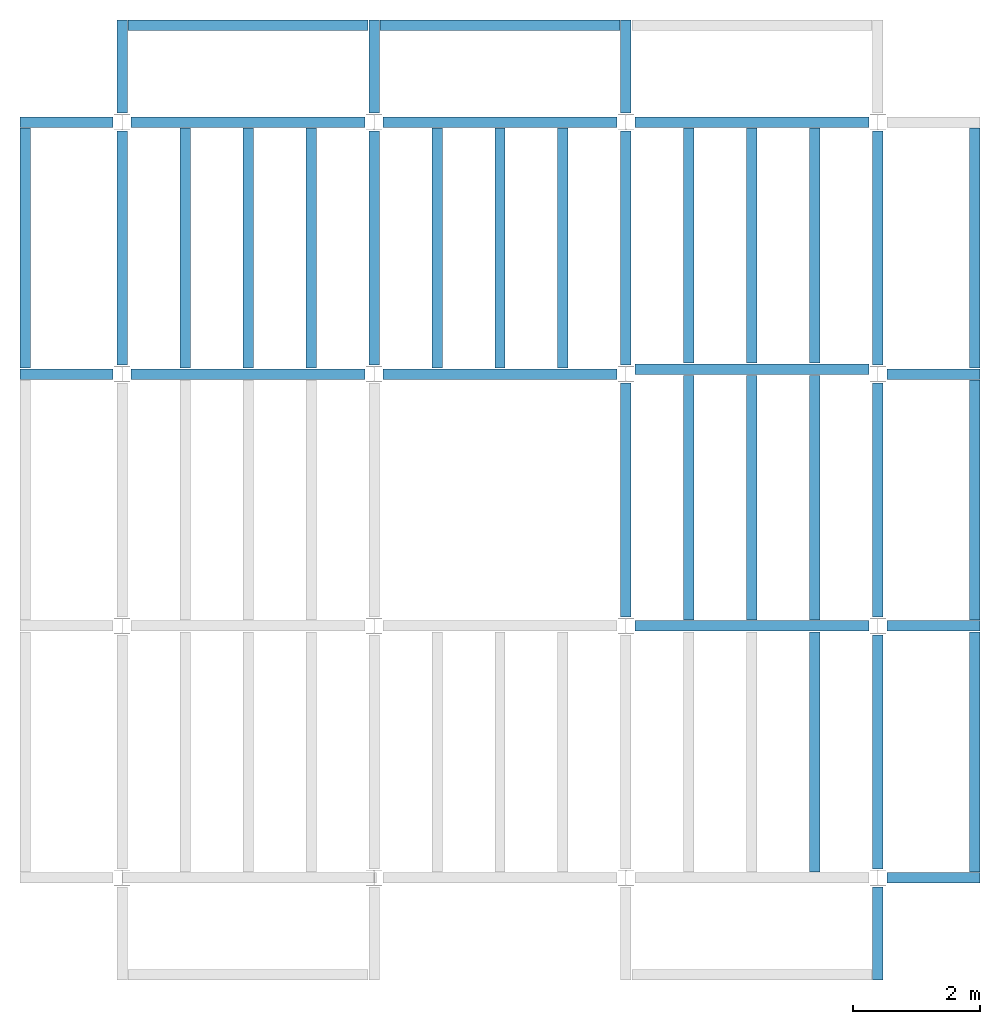
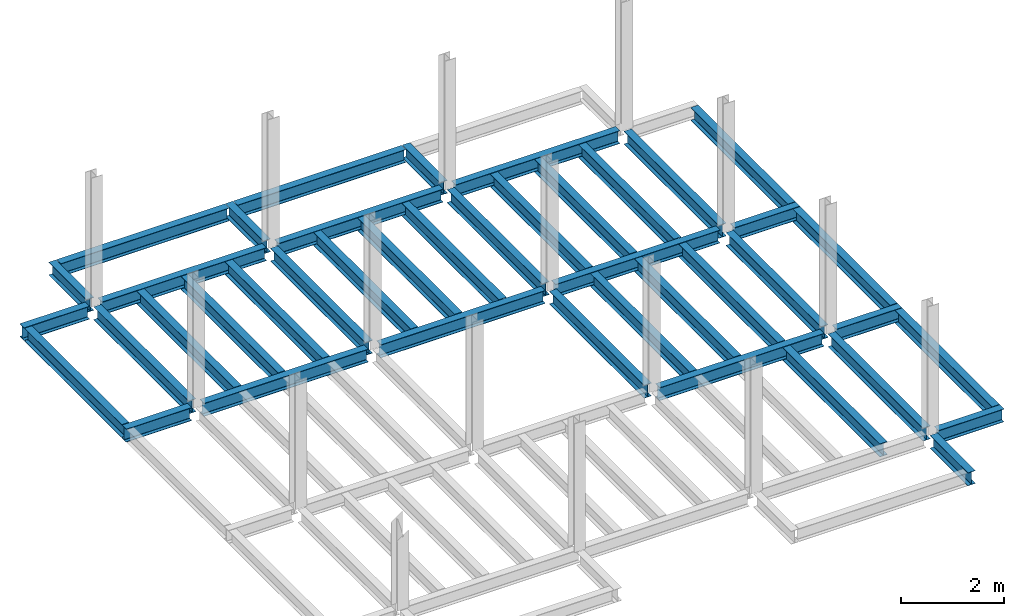
# One storey, part 2 of 3: 42 beams, 5 elements without a shape of their own.
"""IFC4 building model written with IfcOpenShell, lengths in feet."""

from ifc_helpers import new_model, entity, si_unit, converted_unit, derived_unit, direction, frame, origin, place, context, subcontext, project, spatial, line, arc, indexed_curve, outline, extrude, source, transform, mapped, material, type_object, type_shapes, element, aggregate, save


model = new_model("IFC4")

# Units and contexts
model_context = context("Model", 3, precision=0.0001, world=origin(), true_north=direction((6.123233995736766e-17, 1.0)))
plan_context = context("Plan", 3, precision=0.0001, world=origin(), true_north=direction((6.123233995736766e-17, 1.0)))
body_context = subcontext(model_context, "Body", "Model", "MODEL_VIEW")
ifc_project = project(units=[converted_unit("LENGTHUNIT", "FOOT", entity("IfcLengthMeasure", 0.3048), si_unit("LENGTHUNIT", "METRE"), dimensions=[1, 0, 0, 0, 0, 0, 0]), converted_unit("AREAUNIT", "SQUARE FOOT", entity("IfcAreaMeasure", 0.09290304), si_unit("AREAUNIT", "SQUARE_METRE"), dimensions=[2, 0, 0, 0, 0, 0, 0]), converted_unit("PLANEANGLEUNIT", "DEGREE", entity("IfcPlaneAngleMeasure", 0.017453292519943278), si_unit("PLANEANGLEUNIT", "RADIAN"), dimensions=[0, 0, 0, 0, 0, 0, 0]), converted_unit("VOLUMEUNIT", "CUBIC FOOT", entity("IfcVolumeMeasure", 0.028316846592000004), si_unit("VOLUMEUNIT", "CUBIC_METRE"), dimensions=[3, 0, 0, 0, 0, 0, 0]), si_unit("PRESSUREUNIT", "PASCAL"), derived_unit("MASSDENSITYUNIT", [(si_unit("MASSUNIT", "GRAM", prefix="KILO"), 1), (si_unit("LENGTHUNIT", "METRE"), -3)]), derived_unit("VAPORPERMEABILITYUNIT", [(si_unit("LENGTHUNIT", "METRE"), -1), (si_unit("TIMEUNIT", "SECOND"), 1)]), derived_unit("USERDEFINED", [(si_unit("MASSUNIT", "GRAM", prefix="KILO"), 1), (si_unit("LENGTHUNIT", "METRE"), 3), (si_unit("TIMEUNIT", "SECOND"), -3), (si_unit("ELECTRICCURRENTUNIT", "AMPERE"), -2)]), derived_unit("MODULUSOFELASTICITYUNIT", [(si_unit("MASSUNIT", "GRAM", prefix="KILO"), 1), (si_unit("LENGTHUNIT", "METRE"), -1), (si_unit("TIMEUNIT", "SECOND"), -2)]), derived_unit("THERMALEXPANSIONCOEFFICIENTUNIT", [(si_unit("THERMODYNAMICTEMPERATUREUNIT", "KELVIN"), -1)]), derived_unit("SPECIFICHEATCAPACITYUNIT", [(si_unit("TIMEUNIT", "SECOND"), -2), (si_unit("THERMODYNAMICTEMPERATUREUNIT", "KELVIN"), -1), (si_unit("LENGTHUNIT", "METRE"), 2)]), derived_unit("THERMALCONDUCTANCEUNIT", [(si_unit("MASSUNIT", "GRAM", prefix="KILO"), 1), (si_unit("TIMEUNIT", "SECOND"), -3), (si_unit("THERMODYNAMICTEMPERATUREUNIT", "KELVIN"), -1), (si_unit("LENGTHUNIT", "METRE"), 1)])], contexts=[model_context, plan_context])

# Site, building, storey
site_placement = place(None, origin())
site = spatial("IfcSite", under=ifc_project, at=site_placement, CompositionType="ELEMENT")
building_placement = place(site_placement, origin())
building = spatial("IfcBuilding", under=site, at=building_placement, CompositionType="ELEMENT")
storey_placement = place(building_placement, frame((0.0, 0.0, 19.875)))
storey = spatial("IfcBuildingStorey", under=building, at=storey_placement, Name="STR 03", CompositionType="ELEMENT", Elevation=19.875)

# Beams
ifc_material = material(Name="Steel ASTM A992", Category="Metal")
beam_type_1 = type_object("IfcBeamType", Name="W12X26", PredefinedType="JOIST", material=ifc_material)
shared_shape_1 = source(origin(), body_context, "Body", "SweptSolid", [
    extrude(outline(indexed_curve([(-0.27041666666666714, -0.47666666666666574), (-0.27041666666666714, -0.5083333333333351), (0.2704166666666669, -0.5083333333333351), (0.2704166666666669, -0.47666666666666574), (0.03458333333333309, -0.47666666666666574), (0.016905663803669493, -0.46934433619632937), (0.009583333333333202, -0.4516666666666659), (0.0095833333333332, 0.45166666666666705), (0.01690566380366948, 0.4693443361963307), (0.03458333333333325, 0.4766666666666671), (0.2704166666666669, 0.4766666666666671), (0.2704166666666669, 0.5083333333333312), (-0.2704166666666655, 0.5083333333333312), (-0.2704166666666655, 0.4766666666666671), (-0.034583333333333514, 0.47666666666666707), (-0.016905663803669865, 0.46934433619633054), (-0.009583333333333737, 0.45166666666666694), (-0.009583333333333735, -0.4516666666666658), (-0.01690566380367013, -0.4693443361963295), (-0.03458333333333368, -0.47666666666666574)], segments=[line(1, 2, 3, 4, 5), arc(5, 6, 7), line(7, 8), arc(8, 9, 10), line(10, 11, 12, 13, 14, 15), arc(15, 16, 17), line(17, 18), arc(18, 19, 20), line(20, 1)], self_intersect=False)), frame((-6.103346456692914, 0.0, 0.0), z_axis=(-1.0, 0.0, 0.0), x_axis=(0.0, -1.0, 0.0)), (0.0, 0.0, -1.0), 12.083333333333323),
])
type_shapes(beam_type_1, [shared_shape_1])
for number, where, name in (
    (1, (6.561679790026307, 39.0, -0.5083333333333329), "W12X26"),
    (2, (6.561679790026288, 26.0, -0.5083333333333329), "W12X26"),
):
    element("IfcBeam", number, at=place(storey_placement, frame(where)), inside=storey, type_object=beam_type_1, material=ifc_material, Name=name, ObjectType="W Shapes:W12X26", PredefinedType="JOIST", context=body_context, shape_type="MappedRepresentation", body=[
        mapped(shared_shape_1, transform((0.0, 0.0, 0.0), scale=1.0)),
    ])
beam_1_placement = place(storey_placement, frame((39.0, 6.56167979002612, -0.5083333333333329), z_axis=(0.0, 0.0, 1.0), x_axis=(0.0, 1.0, 0.0)))
element("IfcBeam", 3, at=beam_1_placement, inside=storey, type_object=beam_type_1, material=ifc_material, Name="W12X26", ObjectType="W Shapes:W12X26", PredefinedType="JOIST", context=body_context, shape_type="MappedRepresentation", body=[
    mapped(shared_shape_1, transform((0.0, 0.0, 0.0), scale=1.0)),
])
beam_type_2 = type_object("IfcBeamType", Name="W12X26", PredefinedType="JOIST", material=ifc_material)
shared_shape_2 = source(origin(), body_context, "Body", "SweptSolid", [
    extrude(outline(indexed_curve([(-0.27041666666666714, -0.47666666666666574), (-0.27041666666666714, -0.5083333333333351), (0.2704166666666669, -0.5083333333333351), (0.2704166666666669, -0.47666666666666574), (0.03458333333333309, -0.47666666666666574), (0.016905663803669493, -0.46934433619632937), (0.009583333333333202, -0.4516666666666659), (0.0095833333333332, 0.45166666666666705), (0.01690566380366948, 0.4693443361963307), (0.03458333333333325, 0.4766666666666671), (0.2704166666666669, 0.4766666666666671), (0.2704166666666669, 0.5083333333333312), (-0.2704166666666655, 0.5083333333333312), (-0.2704166666666655, 0.4766666666666671), (-0.034583333333333514, 0.47666666666666707), (-0.016905663803669865, 0.46934433619633054), (-0.009583333333333737, 0.45166666666666694), (-0.009583333333333735, -0.4516666666666658), (-0.01690566380367013, -0.4693443361963295), (-0.03458333333333368, -0.47666666666666574)], segments=[line(1, 2, 3, 4, 5), arc(5, 6, 7), line(7, 8), arc(8, 9, 10), line(10, 11, 12, 13, 14, 15), arc(15, 16, 17), line(17, 18), arc(18, 19, 20), line(20, 1)], self_intersect=False)), frame((-6.226706036745409, 0.0, 0.0), z_axis=(-1.0, 0.0, 0.0), x_axis=(0.0, -1.0, 0.0)), (0.0, 0.0, -1.0), 12.08333333333333),
])
type_shapes(beam_type_2, [shared_shape_2])
for number, where, name in (
    (4, (19.685039370078798, 39.0, -0.5083333333333329), "W12X26"),
    (5, (19.68503937007878, 26.0, -0.5083333333333329), "W12X26"),
):
    element("IfcBeam", number, at=place(storey_placement, frame(where)), inside=storey, type_object=beam_type_2, material=ifc_material, Name=name, ObjectType="W Shapes:W12X26", PredefinedType="JOIST", context=body_context, shape_type="MappedRepresentation", body=[
        mapped(shared_shape_2, transform((0.0, 0.0, 0.0), scale=1.0)),
    ])
for number, where, z_axis, x_axis, name in (
    (6, (39.0, 19.685039370078613, -0.5083333333333329), (0.0, 0.0, 1.0), (0.0, 1.0, 0.0), "W12X26"),
    (7, (26.0, 19.685039370078655, -0.5083333333333329), (0.0, 0.0, 1.0), (0.0, 1.0, 0.0), "W12X26"),
):
    element("IfcBeam", number, at=place(storey_placement, frame(where, z_axis=z_axis, x_axis=x_axis)), inside=storey, type_object=beam_type_2, material=ifc_material, Name=name, ObjectType="W Shapes:W12X26", PredefinedType="JOIST", context=body_context, shape_type="MappedRepresentation", body=[
        mapped(shared_shape_2, transform((0.0, 0.0, 0.0), scale=1.0)),
    ])

# Assembly, beams
assembly_1_placement = place(storey_placement, origin())
assembly_1 = element("IfcElementAssembly", 8, at=assembly_1_placement, inside=storey, Name="Structural Framing System", ObjectType="Structural Beam System:Structural Framing System", AssemblyPlace="NOTDEFINED", PredefinedType="BEAM_GRID")
beam_type_3 = type_object("IfcBeamType", Name="W12X26", PredefinedType="JOIST", material=ifc_material)
shared_shape_3 = source(origin(), body_context, "Body", "SweptSolid", [
    extrude(outline(indexed_curve([(-0.27041666666666714, -0.47666666666666574), (-0.27041666666666714, -0.5083333333333351), (0.2704166666666669, -0.5083333333333351), (0.2704166666666669, -0.47666666666666574), (0.03458333333333309, -0.47666666666666574), (0.016905663803669493, -0.46934433619632937), (0.009583333333333202, -0.4516666666666659), (0.0095833333333332, 0.45166666666666705), (0.01690566380366948, 0.4693443361963307), (0.03458333333333325, 0.4766666666666671), (0.2704166666666669, 0.4766666666666671), (0.2704166666666669, 0.5083333333333312), (-0.2704166666666655, 0.5083333333333312), (-0.2704166666666655, 0.4766666666666671), (-0.034583333333333514, 0.47666666666666707), (-0.016905663803669865, 0.46934433619633054), (-0.009583333333333737, 0.45166666666666694), (-0.009583333333333735, -0.4516666666666658), (-0.01690566380367013, -0.4693443361963295), (-0.03458333333333368, -0.47666666666666574)], segments=[line(1, 2, 3, 4, 5), arc(5, 6, 7), line(7, 8), arc(8, 9, 10), line(10, 11, 12, 13, 14, 15), arc(15, 16, 17), line(17, 18), arc(18, 19, 20), line(20, 1)], self_intersect=False)), frame((-6.187916666666566, 0.0, 0.0), z_axis=(-1.0, 0.0, 0.0), x_axis=(0.0, -1.0, 0.0)), (0.0, 0.0, -1.0), 12.375833333333075),
])
type_shapes(beam_type_3, [shared_shape_3])
beam_2_placement = place(assembly_1_placement, frame((3.250000000000073, 32.49999999999969, -0.5083333333333329), z_axis=(0.0, 0.0, 1.0), x_axis=(0.0, 1.0, 0.0)))
beam_2 = element("IfcBeam", 9, at=beam_2_placement, type_object=beam_type_3, material=ifc_material, Name="W12X26", ObjectType="W Shapes:W12X26", PredefinedType="JOIST", context=body_context, shape_type="MappedRepresentation", body=[
    mapped(shared_shape_3, transform((0.0, 0.0, 0.0), scale=1.0)),
])
beam_3_placement = place(assembly_1_placement, frame((6.500000000000094, 32.49999999999967, -0.5083333333333329), z_axis=(0.0, 0.0, 1.0), x_axis=(0.0, 1.0, 0.0)))
beam_3 = element("IfcBeam", 10, at=beam_3_placement, type_object=beam_type_3, material=ifc_material, Name="W12X26", ObjectType="W Shapes:W12X26", PredefinedType="JOIST", context=body_context, shape_type="MappedRepresentation", body=[
    mapped(shared_shape_3, transform((0.0, 0.0, 0.0), scale=1.0)),
])
beam_4_placement = place(assembly_1_placement, frame((9.750000000000115, 32.49999999999966, -0.5083333333333329), z_axis=(0.0, 0.0, 1.0), x_axis=(0.0, 1.0, 0.0)))
beam_4 = element("IfcBeam", 11, at=beam_4_placement, type_object=beam_type_3, material=ifc_material, Name="W12X26", ObjectType="W Shapes:W12X26", PredefinedType="JOIST", context=body_context, shape_type="MappedRepresentation", body=[
    mapped(shared_shape_3, transform((0.0, 0.0, 0.0), scale=1.0)),
])
aggregate(assembly_1, [beam_2, beam_3, beam_4])

assembly_2_placement = place(storey_placement, origin())
assembly_2 = element("IfcElementAssembly", 12, at=assembly_2_placement, inside=storey, Name="Structural Framing System", ObjectType="Structural Beam System:Structural Framing System", AssemblyPlace="NOTDEFINED", PredefinedType="BEAM_GRID")
beam_5_placement = place(assembly_2_placement, frame((16.25000000000014, 32.499999999999645, -0.5083333333333329), z_axis=(0.0, 0.0, 1.0), x_axis=(0.0, 1.0, 0.0)))
beam_5 = element("IfcBeam", 13, at=beam_5_placement, type_object=beam_type_3, material=ifc_material, Name="W12X26", ObjectType="W Shapes:W12X26", PredefinedType="JOIST", context=body_context, shape_type="MappedRepresentation", body=[
    mapped(shared_shape_3, transform((0.0, 0.0, 0.0), scale=1.0)),
])
beam_6_placement = place(assembly_2_placement, frame((19.50000000000014, 32.49999999999963, -0.5083333333333329), z_axis=(0.0, 0.0, 1.0), x_axis=(0.0, 1.0, 0.0)))
beam_6 = element("IfcBeam", 14, at=beam_6_placement, type_object=beam_type_3, material=ifc_material, Name="W12X26", ObjectType="W Shapes:W12X26", PredefinedType="JOIST", context=body_context, shape_type="MappedRepresentation", body=[
    mapped(shared_shape_3, transform((0.0, 0.0, 0.0), scale=1.0)),
])
beam_7_placement = place(assembly_2_placement, frame((22.750000000000142, 32.499999999999616, -0.5083333333333329), z_axis=(0.0, 0.0, 1.0), x_axis=(0.0, 1.0, 0.0)))
beam_7 = element("IfcBeam", 15, at=beam_7_placement, type_object=beam_type_3, material=ifc_material, Name="W12X26", ObjectType="W Shapes:W12X26", PredefinedType="JOIST", context=body_context, shape_type="MappedRepresentation", body=[
    mapped(shared_shape_3, transform((0.0, 0.0, 0.0), scale=1.0)),
])
aggregate(assembly_2, [beam_5, beam_6, beam_7])

# Assembly, beam
assembly_3_placement = place(storey_placement, origin())
assembly_3 = element("IfcElementAssembly", 16, at=assembly_3_placement, inside=storey, Name="Structural Framing System", ObjectType="Structural Beam System:Structural Framing System", AssemblyPlace="NOTDEFINED", PredefinedType="BEAM_GRID")
beam_8_placement = place(assembly_3_placement, frame((35.7500000000001, 6.499999999999728, -0.5083333333333329), z_axis=(0.0, 0.0, 1.0), x_axis=(0.0, 1.0, 0.0)))
beam_8 = element("IfcBeam", 17, at=beam_8_placement, type_object=beam_type_3, material=ifc_material, Name="W12X26", ObjectType="W Shapes:W12X26", PredefinedType="JOIST", context=body_context, shape_type="MappedRepresentation", body=[
    mapped(shared_shape_3, transform((0.0, 0.0, 0.0), scale=1.0)),
])
aggregate(assembly_3, [beam_8])

# Beams
for number, where, z_axis, x_axis, name in (
    (18, (-5.0, 32.4999999999997, -0.5083333333314926), (0.0, 0.0, 1.0), (0.0, 1.0, 0.0), "W12X26"),
    (19, (44.0, 6.4999999999997, -0.5083333333314926), (0.0, 0.0, 1.0), (0.0, 1.0, 0.0), "W12X26"),
    (20, (44.0, 19.499999999999545, -0.5083333333314926), (0.0, 0.0, 1.0), (0.0, 1.0, 0.0), "W12X26"),
    (21, (44.0, 32.499999999999545, -0.5083333333314926), (0.0, 0.0, 1.0), (0.0, 1.0, 0.0), "W12X26"),
):
    element("IfcBeam", number, at=place(storey_placement, frame(where, z_axis=z_axis, x_axis=x_axis)), inside=storey, type_object=beam_type_3, material=ifc_material, Name=name, ObjectType="W Shapes:W12X26", PredefinedType="JOIST", context=body_context, shape_type="MappedRepresentation", body=[
        mapped(shared_shape_3, transform((0.0, 0.0, 0.0), scale=1.0)),
    ])
beam_9_placement = place(storey_placement, frame((6.5000000000001625, 44.0, -0.5083333333314926)))
element("IfcBeam", 22, at=beam_9_placement, inside=storey, type_object=beam_type_3, material=ifc_material, Name="W Shapes:W12X26", ObjectType="W Shapes:W12X26", PredefinedType="JOIST", context=body_context, shape_type="MappedRepresentation", body=[
    mapped(shared_shape_3, transform((0.0, 0.0, 0.0), scale=1.0)),
])

# Assembly, beams
assembly_4_placement = place(storey_placement, origin())
assembly_4 = element("IfcElementAssembly", 23, at=assembly_4_placement, inside=storey, Name="Structural Framing System", ObjectType="Structural Beam System:Structural Framing System", AssemblyPlace="NOTDEFINED", PredefinedType="BEAM_GRID")
beam_type_4 = type_object("IfcBeamType", Name="W12X26", PredefinedType="JOIST", material=ifc_material)
shared_shape_4 = source(origin(), body_context, "Body", "SweptSolid", [
    extrude(outline(indexed_curve([(-0.27041666666666714, -0.47666666666666574), (-0.27041666666666714, -0.5083333333333351), (0.2704166666666669, -0.5083333333333351), (0.2704166666666669, -0.47666666666666574), (0.03458333333333309, -0.47666666666666574), (0.016905663803669486, -0.46934433619632937), (0.009583333333333202, -0.4516666666666659), (0.0095833333333332, 0.45166666666666705), (0.016905663803669476, 0.4693443361963307), (0.03458333333333325, 0.4766666666666671), (0.2704166666666669, 0.4766666666666671), (0.2704166666666669, 0.5083333333333312), (-0.2704166666666655, 0.5083333333333312), (-0.2704166666666655, 0.4766666666666671), (-0.034583333333333514, 0.47666666666666707), (-0.016905663803669875, 0.46934433619633054), (-0.009583333333333737, 0.45166666666666694), (-0.009583333333333735, -0.4516666666666658), (-0.016905663803670125, -0.4693443361963295), (-0.03458333333333368, -0.47666666666666574)], segments=[line(1, 2, 3, 4, 5), arc(5, 6, 7), line(7, 8), arc(8, 9, 10), line(10, 11, 12, 13, 14, 15), arc(15, 16, 17), line(17, 18), arc(18, 19, 20), line(20, 1)], self_intersect=False)), frame((-6.311276246719372, 0.0, 0.0), z_axis=(-1.0, 0.0, 0.0), x_axis=(0.0, -1.0, 0.0)), (0.0, 0.0, -1.0), 12.622552493438683),
])
type_shapes(beam_type_4, [shared_shape_4])
beam_10_placement = place(assembly_4_placement, frame((29.25000000000012, 19.623359580052245, -0.5083333333333329), z_axis=(0.0, 0.0, 1.0), x_axis=(0.0, 1.0, 0.0)))
beam_10 = element("IfcBeam", 24, at=beam_10_placement, type_object=beam_type_4, material=ifc_material, Name="W12X26", ObjectType="W Shapes:W12X26", PredefinedType="JOIST", context=body_context, shape_type="MappedRepresentation", body=[
    mapped(shared_shape_4, transform((0.0, 0.0, 0.0), scale=1.0)),
])
beam_11_placement = place(assembly_4_placement, frame((32.500000000000114, 19.62335958005223, -0.5083333333333329), z_axis=(0.0, 0.0, 1.0), x_axis=(0.0, 1.0, 0.0)))
beam_11 = element("IfcBeam", 25, at=beam_11_placement, type_object=beam_type_4, material=ifc_material, Name="W12X26", ObjectType="W Shapes:W12X26", PredefinedType="JOIST", context=body_context, shape_type="MappedRepresentation", body=[
    mapped(shared_shape_4, transform((0.0, 0.0, 0.0), scale=1.0)),
])
beam_12_placement = place(assembly_4_placement, frame((35.750000000000114, 19.623359580052224, -0.5083333333333329), z_axis=(0.0, 0.0, 1.0), x_axis=(0.0, 1.0, 0.0)))
beam_12 = element("IfcBeam", 26, at=beam_12_placement, type_object=beam_type_4, material=ifc_material, Name="W12X26", ObjectType="W Shapes:W12X26", PredefinedType="JOIST", context=body_context, shape_type="MappedRepresentation", body=[
    mapped(shared_shape_4, transform((0.0, 0.0, 0.0), scale=1.0)),
])
aggregate(assembly_4, [beam_10, beam_11, beam_12])

assembly_5_placement = place(storey_placement, origin())
assembly_5 = element("IfcElementAssembly", 27, at=assembly_5_placement, inside=storey, Name="Structural Framing System", ObjectType="Structural Beam System:Structural Framing System", AssemblyPlace="NOTDEFINED", PredefinedType="BEAM_GRID")
beam_type_5 = type_object("IfcBeamType", Name="W12X26", PredefinedType="JOIST", material=ifc_material)
shared_shape_5 = source(origin(), body_context, "Body", "SweptSolid", [
    extrude(outline(indexed_curve([(-0.27041666666666714, -0.47666666666666574), (-0.27041666666666714, -0.5083333333333351), (0.2704166666666669, -0.5083333333333351), (0.2704166666666669, -0.47666666666666574), (0.03458333333333309, -0.47666666666666574), (0.016905663803669486, -0.46934433619632937), (0.009583333333333202, -0.4516666666666659), (0.0095833333333332, 0.45166666666666705), (0.016905663803669476, 0.4693443361963307), (0.03458333333333325, 0.4766666666666671), (0.2704166666666669, 0.4766666666666671), (0.2704166666666669, 0.5083333333333312), (-0.2704166666666655, 0.5083333333333312), (-0.2704166666666655, 0.4766666666666671), (-0.034583333333333514, 0.47666666666666707), (-0.016905663803669875, 0.46934433619633054), (-0.009583333333333737, 0.45166666666666694), (-0.009583333333333735, -0.4516666666666658), (-0.016905663803670125, -0.4693443361963295), (-0.03458333333333368, -0.47666666666666574)], segments=[line(1, 2, 3, 4, 5), arc(5, 6, 7), line(7, 8), arc(8, 9, 10), line(10, 11, 12, 13, 14, 15), arc(15, 16, 17), line(17, 18), arc(18, 19, 20), line(20, 1)], self_intersect=False)), frame((-6.0645570866140766, 0.0, 0.0), z_axis=(-1.0, 0.0, 0.0), x_axis=(0.0, -1.0, 0.0)), (0.0, 0.0, -1.0), 12.129114173228096),
])
type_shapes(beam_type_5, [shared_shape_5])
beam_13_placement = place(assembly_5_placement, frame((29.250000000000142, 32.623359580052245, -0.5083333333333329), z_axis=(0.0, 0.0, 1.0), x_axis=(0.0, 1.0, 0.0)))
beam_13 = element("IfcBeam", 28, at=beam_13_placement, type_object=beam_type_5, material=ifc_material, Name="W12X26", ObjectType="W Shapes:W12X26", PredefinedType="JOIST", context=body_context, shape_type="MappedRepresentation", body=[
    mapped(shared_shape_5, transform((0.0, 0.0, 0.0), scale=1.0)),
])
beam_14_placement = place(assembly_5_placement, frame((32.50000000000014, 32.62335958005224, -0.5083333333333329), z_axis=(0.0, 0.0, 1.0), x_axis=(0.0, 1.0, 0.0)))
beam_14 = element("IfcBeam", 29, at=beam_14_placement, type_object=beam_type_5, material=ifc_material, Name="W12X26", ObjectType="W Shapes:W12X26", PredefinedType="JOIST", context=body_context, shape_type="MappedRepresentation", body=[
    mapped(shared_shape_5, transform((0.0, 0.0, 0.0), scale=1.0)),
])
beam_15_placement = place(assembly_5_placement, frame((35.75000000000014, 32.623359580052224, -0.5083333333333329), z_axis=(0.0, 0.0, 1.0), x_axis=(0.0, 1.0, 0.0)))
beam_15 = element("IfcBeam", 30, at=beam_15_placement, type_object=beam_type_5, material=ifc_material, Name="W12X26", ObjectType="W Shapes:W12X26", PredefinedType="JOIST", context=body_context, shape_type="MappedRepresentation", body=[
    mapped(shared_shape_5, transform((0.0, 0.0, 0.0), scale=1.0)),
])
aggregate(assembly_5, [beam_13, beam_14, beam_15])

# Beams
beam_type_6 = type_object("IfcBeamType", Name="W12X26", PredefinedType="JOIST", material=ifc_material)
shared_shape_6 = source(origin(), body_context, "Body", "SweptSolid", [
    extrude(outline(indexed_curve([(-0.27041666666666714, -0.47666666666666574), (-0.27041666666666714, -0.5083333333333351), (0.2704166666666669, -0.5083333333333351), (0.2704166666666669, -0.47666666666666574), (0.03458333333333309, -0.47666666666666574), (0.016905663803669493, -0.46934433619632937), (0.009583333333333202, -0.4516666666666659), (0.0095833333333332, 0.45166666666666705), (0.01690566380366948, 0.4693443361963307), (0.03458333333333325, 0.4766666666666671), (0.2704166666666669, 0.4766666666666671), (0.2704166666666669, 0.5083333333333312), (-0.2704166666666655, 0.5083333333333312), (-0.2704166666666655, 0.4766666666666671), (-0.034583333333333514, 0.47666666666666707), (-0.016905663803669865, 0.46934433619633054), (-0.009583333333333737, 0.45166666666666694), (-0.009583333333333735, -0.4516666666666658), (-0.01690566380367013, -0.4693443361963295), (-0.03458333333333368, -0.47666666666666574)], segments=[line(1, 2, 3, 4, 5), arc(5, 6, 7), line(7, 8), arc(8, 9, 10), line(10, 11, 12, 13, 14, 15), arc(15, 16, 17), line(17, 18), arc(18, 19, 20), line(20, 1)], self_intersect=False)), frame((-6.165026246719308, 0.0, 0.0), z_axis=(-1.0, 0.0, 0.0), x_axis=(0.0, -1.0, 0.0)), (0.0, 0.0, -1.0), 12.08333333333334),
])
type_shapes(beam_type_6, [shared_shape_6])
for number, where, name in (
    (31, (32.6233595800526, 39.0, -0.5083333333333329), "W12X26"),
    (32, (32.62335958005258, 26.24671916010488, -0.5083333333333329), "W12X26"),
    (33, (32.62335958005255, 13.0, -0.5083333333333329), "W12X26"),
):
    element("IfcBeam", number, at=place(storey_placement, frame(where)), inside=storey, type_object=beam_type_6, material=ifc_material, Name=name, ObjectType="W Shapes:W12X26", PredefinedType="JOIST", context=body_context, shape_type="MappedRepresentation", body=[
        mapped(shared_shape_6, transform((0.0, 0.0, 0.0), scale=1.0)),
    ])
for number, where, z_axis, x_axis, name in (
    (34, (39.0, 32.62335958005221, -0.5083333333333329), (0.0, 0.0, 1.0), (0.0, 1.0, 0.0), "W12X26"),
    (35, (26.0, 32.62335958005225, -0.5083333333333329), (0.0, 0.0, 1.0), (0.0, 1.0, 0.0), "W12X26"),
    (36, (13.0, 32.623359580052295, -0.5083333333333329), (0.0, 0.0, 1.0), (0.0, 1.0, 0.0), "W12X26"),
    (37, (0.0, 32.62335958005234, -0.5083333333333329), (0.0, 0.0, 1.0), (0.0, 1.0, 0.0), "W12X26"),
):
    element("IfcBeam", number, at=place(storey_placement, frame(where, z_axis=z_axis, x_axis=x_axis)), inside=storey, type_object=beam_type_6, material=ifc_material, Name=name, ObjectType="W Shapes:W12X26", PredefinedType="JOIST", context=body_context, shape_type="MappedRepresentation", body=[
        mapped(shared_shape_6, transform((0.0, 0.0, 0.0), scale=1.0)),
    ])
beam_type_7 = type_object("IfcBeamType", Name="W12X26", PredefinedType="JOIST", material=ifc_material)
shared_shape_7 = source(origin(), body_context, "Body", "SweptSolid", [
    extrude(outline(indexed_curve([(0.47666666666666574, -0.2704166666666672), (0.5083333333333351, -0.2704166666666672), (0.5083333333333351, 0.27041666666666686), (0.47666666666666574, 0.27041666666666686), (0.47666666666666574, 0.03458333333333307), (0.46934433619632937, 0.016905663803669473), (0.4516666666666659, 0.00958333333333318), (-0.45166666666666705, 0.00958333333333318), (-0.4693443361963307, 0.01690566380366946), (-0.4766666666666671, 0.03458333333333323), (-0.4766666666666671, 0.27041666666666686), (-0.5083333333333312, 0.27041666666666686), (-0.5083333333333312, -0.27041666666666553), (-0.4766666666666671, -0.27041666666666553), (-0.47666666666666707, -0.034583333333333535), (-0.46934433619633054, -0.016905663803669885), (-0.45166666666666694, -0.00958333333333376), (0.4516666666666658, -0.009583333333333756), (0.4693443361963295, -0.01690566380367015), (0.47666666666666574, -0.0345833333333337)], segments=[line(1, 2, 3, 4, 5), arc(5, 6, 7), line(7, 8), arc(8, 9, 10), line(10, 11, 12, 13, 14, 15), arc(15, 16, 17), line(17, 18), arc(18, 19, 20), line(20, 1)], self_intersect=False)), frame((-2.0416666666666208, 0.0, 0.0), z_axis=(1.0, 0.0, 0.0), x_axis=(0.0, 0.0, -1.0)), (0.0, 0.0, 1.0), 4.812083333333336),
])
type_shapes(beam_type_7, [shared_shape_7])
for number, where, z_axis, x_axis, name in (
    (38, (-2.4999999999998104, 39.0, -0.5083333333314926), (0.0, 0.0, 1.0), (-1.0, 0.0, 0.0), "W12X26"),
    (39, (39.0, -2.50000000000058, -0.5083333333314926), (0.0, 0.0, 1.0), (0.0, -1.0, 0.0), "W12X26"),
    (40, (-2.4999999999998317, 26.0, -0.5083333333314926), (0.0, 0.0, 1.0), (-1.0, 0.0, 0.0), "W12X26"),
):
    element("IfcBeam", number, at=place(storey_placement, frame(where, z_axis=z_axis, x_axis=x_axis)), inside=storey, type_object=beam_type_7, material=ifc_material, Name=name, ObjectType="W Shapes:W12X26", PredefinedType="JOIST", context=body_context, shape_type="MappedRepresentation", body=[
        mapped(shared_shape_7, transform((0.0, 0.0, 0.0), scale=1.0)),
    ])
beam_type_8 = type_object("IfcBeamType", Name="W12X26", PredefinedType="JOIST", material=ifc_material)
shared_shape_8 = source(origin(), body_context, "Body", "SweptSolid", [
    extrude(outline(indexed_curve([(0.47666666666666574, -0.2704166666666672), (0.5083333333333351, -0.2704166666666672), (0.5083333333333351, 0.27041666666666686), (0.47666666666666574, 0.27041666666666686), (0.47666666666666574, 0.03458333333333307), (0.46934433619632937, 0.016905663803669473), (0.4516666666666659, 0.00958333333333318), (-0.45166666666666705, 0.00958333333333318), (-0.4693443361963307, 0.01690566380366946), (-0.4766666666666671, 0.03458333333333323), (-0.4766666666666671, 0.27041666666666686), (-0.5083333333333312, 0.27041666666666686), (-0.5083333333333312, -0.27041666666666553), (-0.4766666666666671, -0.27041666666666553), (-0.47666666666666707, -0.034583333333333535), (-0.46934433619633054, -0.016905663803669885), (-0.45166666666666694, -0.00958333333333376), (0.4516666666666658, -0.009583333333333756), (0.4693443361963295, -0.01690566380367015), (0.47666666666666574, -0.0345833333333337)], segments=[line(1, 2, 3, 4, 5), arc(5, 6, 7), line(7, 8), arc(8, 9, 10), line(10, 11, 12, 13, 14, 15), arc(15, 16, 17), line(17, 18), arc(18, 19, 20), line(20, 1)], self_intersect=False)), frame((-2.77041666666672, 0.0, 0.0), z_axis=(1.0, 0.0, 0.0), x_axis=(0.0, 0.0, -1.0)), (0.0, 0.0, 1.0), 4.812083333333389),
])
type_shapes(beam_type_8, [shared_shape_8])
for number, where, z_axis, x_axis, name in (
    (41, (41.50000000000013, 26.0, -0.5083333333314926), (0.0, 0.0, 1.0), (-1.0, 0.0, 0.0), "W12X26"),
    (42, (41.50000000000011, 13.0, -0.5083333333314926), (0.0, 0.0, 1.0), (-1.0, 0.0, 0.0), "W12X26"),
    (43, (41.500000000000085, 0.0, -0.5083333333314926), (0.0, 0.0, 1.0), (-1.0, 0.0, 0.0), "W12X26"),
    (44, (13.0, 41.49999999999965, -0.5083333333314926), (0.0, 0.0, 1.0), (0.0, -1.0, 0.0), "W12X26"),
    (45, (0.0, 41.499999999999694, -0.5083333333314926), (0.0, 0.0, 1.0), (0.0, -1.0, 0.0), "W12X26"),
):
    element("IfcBeam", number, at=place(storey_placement, frame(where, z_axis=z_axis, x_axis=x_axis)), inside=storey, type_object=beam_type_8, material=ifc_material, Name=name, ObjectType="W Shapes:W12X26", PredefinedType="JOIST", context=body_context, shape_type="MappedRepresentation", body=[
        mapped(shared_shape_8, transform((0.0, 0.0, 0.0), scale=1.0)),
    ])
beam_type_9 = type_object("IfcBeamType", Name="W12X26", PredefinedType="JOIST", material=ifc_material)
shared_shape_9 = source(origin(), body_context, "Body", "SweptSolid", [
    extrude(outline(indexed_curve([(0.47666666666666574, -0.2704166666666672), (0.5083333333333351, -0.2704166666666672), (0.5083333333333351, 0.27041666666666686), (0.47666666666666574, 0.27041666666666686), (0.47666666666666574, 0.03458333333333307), (0.46934433619632937, 0.016905663803669473), (0.4516666666666659, 0.00958333333333318), (-0.45166666666666705, 0.00958333333333318), (-0.4693443361963307, 0.01690566380366946), (-0.4766666666666671, 0.03458333333333323), (-0.4766666666666671, 0.27041666666666686), (-0.5083333333333312, 0.27041666666666686), (-0.5083333333333312, -0.27041666666666553), (-0.4766666666666671, -0.27041666666666553), (-0.47666666666666707, -0.034583333333333535), (-0.46934433619633054, -0.016905663803669885), (-0.45166666666666694, -0.00958333333333376), (0.4516666666666658, -0.009583333333333756), (0.4693443361963295, -0.01690566380367015), (0.47666666666666574, -0.0345833333333337)], segments=[line(1, 2, 3, 4, 5), arc(5, 6, 7), line(7, 8), arc(8, 9, 10), line(10, 11, 12, 13, 14, 15), arc(15, 16, 17), line(17, 18), arc(18, 19, 20), line(20, 1)], self_intersect=False)), frame((-6.187916666666685, 0.0, 0.0), z_axis=(1.0, 0.0, 0.0), x_axis=(0.0, 0.0, -1.0)), (0.0, 0.0, 1.0), 12.375833333333318),
])
type_shapes(beam_type_9, [shared_shape_9])
beam_16_placement = place(storey_placement, frame((19.500000000000142, 44.0, -0.5083333333314926), z_axis=(0.0, 0.0, 1.0), x_axis=(-1.0, 0.0, 0.0)))
element("IfcBeam", 46, at=beam_16_placement, inside=storey, type_object=beam_type_9, material=ifc_material, Name="W Shapes:W12X26", ObjectType="W Shapes:W12X26", PredefinedType="JOIST", context=body_context, shape_type="MappedRepresentation", body=[
    mapped(shared_shape_9, transform((0.0, 0.0, 0.0), scale=1.0)),
])
beam_type_10 = type_object("IfcBeamType", Name="W12X26", PredefinedType="JOIST", material=ifc_material)
shared_shape_10 = source(origin(), body_context, "Body", "SweptSolid", [
    extrude(outline(indexed_curve([(-0.2704166666666694, -0.5083333333333258), (0.27041666666666586, -0.5083333333333258), (0.2704166666666623, -0.476666666666663), (0.034583333333333854, -0.47666666666665947), (0.016905663803669313, -0.46934433619632543), (0.009583333333335275, -0.4516666666666609), (0.009583333333335275, 0.45166666666667155), (0.016905663803669313, 0.4693443361963361), (0.034583333333333854, 0.4766666666666701), (0.2704166666666694, 0.4766666666666701), (0.27041666666666586, 0.50833333333334), (-0.27041666666666586, 0.50833333333334), (-0.27041666666666586, 0.4766666666666701), (-0.0345833333333303, 0.4766666666666701), (-0.01690566380366576, 0.4693443361963361), (-0.009583333333331723, 0.45166666666667155), (-0.009583333333331723, -0.4516666666666609), (-0.01690566380366576, -0.46934433619632543), (-0.034583333333333854, -0.476666666666663), (-0.27041666666666586, -0.476666666666663)], segments=[line(1, 2, 3, 4), arc(4, 5, 6), line(6, 7), arc(7, 8, 9), line(9, 10, 11, 12, 13, 14), arc(14, 15, 16), line(16, 17), arc(17, 18, 19), line(19, 20, 1)], self_intersect=False)), frame((26.0, 44.27041666666632, 19.366666666668497), z_axis=(0.0, -1.0, 0.0), x_axis=(-1.0, 0.0, 0.0)), (0.0, 0.0, 1.0), 4.812083333333393),
])
type_shapes(beam_type_10, [shared_shape_10])
beam_17_placement = place(storey_placement, frame((0.0, 0.0, -19.875)))
element("IfcBeam", 47, at=beam_17_placement, inside=storey, type_object=beam_type_10, material=ifc_material, Name="W12X26", ObjectType="W Shapes:W12X26", PredefinedType="JOIST", context=body_context, shape_type="MappedRepresentation", body=[
    mapped(shared_shape_10, transform((0.0, 0.0, 0.0), scale=1.0)),
])

save(model, "model.ifc")
